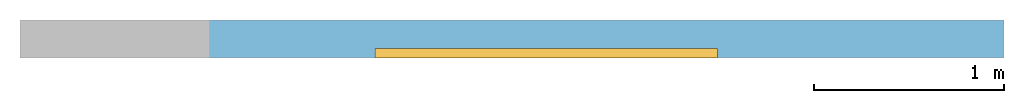
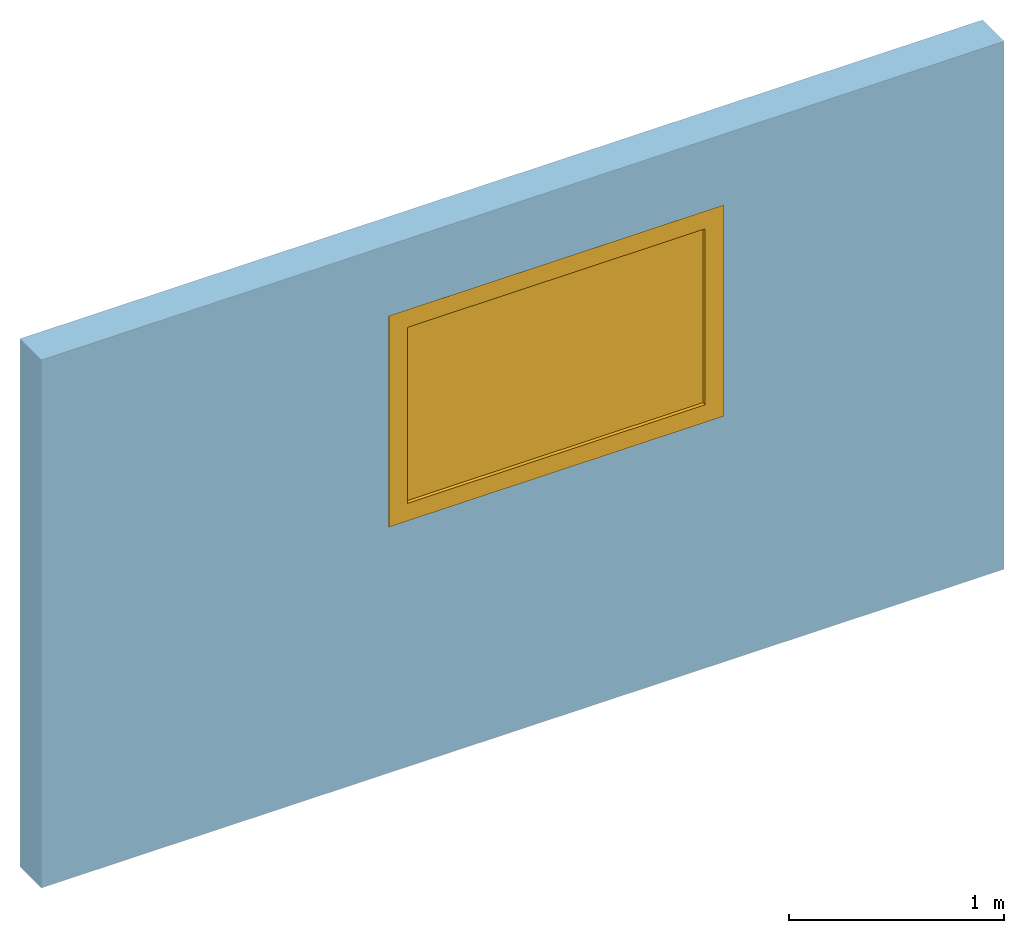
# One storey, part 2 of 2: 1 window, 1 opening, plus 1 element that does not belong to this part.
"""IFC4 building model written with IfcOpenShell, lengths in millimetres."""

import ifcopenshell
import ifcopenshell.guid

model = None  # the IFC model being written
_history = None  # IfcOwnerHistory: only IFC2X3 demands one
_inside = {}  # id of a spatial element -> (the spatial element, [elements in it])
_under = {}  # id of a project, library or spatial element -> (it, [spatial elements below it])
_declared = {}  # id of a project -> (the project, [libraries it declares])
_typed = {}  # id of a type object -> (the type object, [elements of that type])
_made_of = {}  # id of a material, layer set ... -> (it, [elements and type objects made of it])


def new_model(schema):
    """Start an empty IFC model of exactly this schema.

    Asked for "IFC4X3", IfcOpenShell would pick the latest addendum, in which some entities
    have other attributes; the version numbers below select the first issue.
    IFC2X3 requires an IfcOwnerHistory on every rooted entity: one is made here for all.
    """
    global model, _history
    if schema == "IFC4X3":
        model = ifcopenshell.file(schema_version=(4, 3, 0, 0))
    else:
        model = ifcopenshell.file(schema=schema)
    _inside.clear()
    _under.clear()
    _declared.clear()
    _typed.clear()
    _made_of.clear()
    _history = None
    if model.schema == "IFC2X3":
        org = make("IfcOrganization", Name="unknown")
        user = make(
            "IfcPersonAndOrganization",
            ThePerson=make("IfcPerson", FamilyName="unknown"),
            TheOrganization=org,
        )
        app = make(
            "IfcApplication",
            ApplicationDeveloper=org,
            Version="unknown",
            ApplicationFullName="unknown",
            ApplicationIdentifier="unknown",
        )
        _history = make(
            "IfcOwnerHistory",
            OwningUser=user,
            OwningApplication=app,
            ChangeAction="ADDED",
            CreationDate=0,
        )
    return model


def make(cls, **values):
    """One entity of the class cls with the attributes given. An attribute that is None is left unset."""
    return model.create_entity(
        cls, **{name: value for name, value in values.items() if value is not None}
    )


def entity(cls, *values):
    """Any entity or typed value of the class cls, its attributes in the order of the schema. None: left unset."""
    e = model.create_entity(cls)
    for i, value in enumerate(values):
        if value is not None:
            e[i] = value
    return e


def rooted(cls, **values):
    """An entity with a GlobalId (a new one), such as an element, a storey or a relation."""
    return make(cls, GlobalId=ifcopenshell.guid.new(), OwnerHistory=_history, **values)


def si_unit(unit_type, name, prefix=None):
    """IfcSIUnit, for example si_unit("LENGTHUNIT", "METRE", prefix="MILLI")."""
    return make("IfcSIUnit", UnitType=unit_type, Prefix=prefix, Name=name)


def converted_unit(unit_type, name, factor, base, dimensions=None, offset=None):
    """IfcConversionBasedUnit, such as the inch: factor (a typed value) times the base unit."""
    return make(
        "IfcConversionBasedUnit"
        if offset is None
        else "IfcConversionBasedUnitWithOffset",
        ConversionOffset=offset,
        Dimensions=None
        if dimensions is None
        else entity("IfcDimensionalExponents", *dimensions),
        UnitType=unit_type,
        Name=name,
        ConversionFactor=make(
            "IfcMeasureWithUnit", ValueComponent=factor, UnitComponent=base
        ),
    )


def assignment(units):
    """IfcUnitAssignment: the units of a project."""
    return None if units is None else make("IfcUnitAssignment", Units=units)


def point(xyz):
    """IfcCartesianPoint."""
    return None if xyz is None else make("IfcCartesianPoint", Coordinates=xyz)


def direction(xyz):
    """IfcDirection."""
    return None if xyz is None else make("IfcDirection", DirectionRatios=xyz)


def frame(location, z_axis=None, x_axis=None):
    """IfcAxis2Placement3D, a coordinate frame: its origin and axes. An axis left out is left unset."""
    return make(
        "IfcAxis2Placement3D",
        Location=point(location),
        Axis=direction(z_axis),
        RefDirection=direction(x_axis),
    )


def frame_2d(location, x_axis=None):
    """IfcAxis2Placement2D, a coordinate frame in the plane: its origin and x axis."""
    return make(
        "IfcAxis2Placement2D", Location=point(location), RefDirection=direction(x_axis)
    )


def origin_with_axes():
    """The frame at (0, 0, 0) with the z axis (0, 0, 1) and the x axis (1, 0, 0) written out."""
    return frame((0.0, 0.0, 0.0), z_axis=(0.0, 0.0, 1.0), x_axis=(1.0, 0.0, 0.0))


def place(relative_to, where):
    """IfcLocalPlacement: puts the frame where relative to a parent placement (None: the world)."""
    return make(
        "IfcLocalPlacement", PlacementRelTo=relative_to, RelativePlacement=where
    )


def context(
    kind, dimensions, precision=None, world=None, true_north=None, identifier=None
):
    """IfcGeometricRepresentationContext, for example the 3D "Model" context."""
    return make(
        "IfcGeometricRepresentationContext",
        ContextIdentifier=identifier,
        ContextType=kind,
        CoordinateSpaceDimension=dimensions,
        Precision=precision,
        WorldCoordinateSystem=world,
        TrueNorth=true_north,
    )


def subcontext(parent, identifier, kind, view, scale=None):
    """IfcGeometricRepresentationSubContext, for example "Body" below "Model"."""
    return make(
        "IfcGeometricRepresentationSubContext",
        ContextIdentifier=identifier,
        ContextType=kind,
        ParentContext=parent,
        TargetScale=scale,
        TargetView=view,
    )


def project(units=None, contexts=None):
    """IfcProject with its units and contexts."""
    return rooted(
        "IfcProject",
        Name="project",
        RepresentationContexts=contexts,
        UnitsInContext=assignment(units),
    )


def spatial(cls, under=None, at=None, **own):
    """A site, building, storey or space (cls), placed at a placement, below another one or the project."""
    s = rooted(cls, ObjectPlacement=at, **own)
    if under is not None:
        _under.setdefault(under.id(), (under, []))[1].append(s)
    return s


def polyline(points):
    """IfcPolyline through the points."""
    return make("IfcPolyline", Points=[point(p) for p in points])


def point_list(points):
    """IfcCartesianPointList2D or 3D."""
    cls = (
        "IfcCartesianPointList2D" if len(points[0]) == 2 else "IfcCartesianPointList3D"
    )
    return make(cls, CoordList=points)


def outline(outer, holes=None, kind="AREA"):
    """IfcArbitraryClosedProfileDef: a profile drawn as a closed curve; with holes, ...WithVoids."""
    if holes is None:
        return make("IfcArbitraryClosedProfileDef", ProfileType=kind, OuterCurve=outer)
    return make(
        "IfcArbitraryProfileDefWithVoids",
        ProfileType=kind,
        OuterCurve=outer,
        InnerCurves=holes,
    )


def extrude(swept, where, along, depth):
    """IfcExtrudedAreaSolid: the profile swept, set in the frame where, extruded along a direction by depth."""
    return make(
        "IfcExtrudedAreaSolid",
        SweptArea=swept,
        Position=where,
        ExtrudedDirection=direction(along),
        Depth=depth,
    )


def polygons(points, faces, closed=None, point_numbers=None):
    """IfcPolygonalFaceSet: a face is its outer loop, then its inner loops; points numbered from 1."""
    made = []
    for loops in faces:
        if len(loops) == 1:
            made.append(make("IfcIndexedPolygonalFace", CoordIndex=loops[0]))
        else:
            made.append(
                make(
                    "IfcIndexedPolygonalFaceWithVoids",
                    CoordIndex=loops[0],
                    InnerCoordIndices=loops[1:],
                )
            )
    return make(
        "IfcPolygonalFaceSet",
        Coordinates=point_list(points),
        Closed=closed,
        Faces=made,
        PnIndex=point_numbers,
    )


def shape(context_of_items, identifier, shape_type, items):
    """IfcShapeRepresentation: the items that make up one representation, for example the "Body"."""
    return make(
        "IfcShapeRepresentation",
        ContextOfItems=context_of_items,
        RepresentationIdentifier=identifier,
        RepresentationType=shape_type,
        Items=items,
    )


def source(mapping_origin, context_of_items, identifier, shape_type, items):
    """IfcRepresentationMap: a shape defined once, which mapped items show again and again."""
    return make(
        "IfcRepresentationMap",
        MappingOrigin=mapping_origin,
        MappedRepresentation=shape(context_of_items, identifier, shape_type, items),
    )


def transform(
    local_origin,
    x_axis=None,
    y_axis=None,
    z_axis=None,
    scale=None,
    scale2=None,
    scale3=None,
    uniform=True,
):
    """IfcCartesianTransformationOperator3D, or its non-uniform kind. x_axis, y_axis, z_axis: its Axis1, 2, 3."""
    if uniform:
        return make(
            "IfcCartesianTransformationOperator3D",
            Axis1=direction(x_axis),
            Axis2=direction(y_axis),
            LocalOrigin=point(local_origin),
            Scale=scale,
            Axis3=direction(z_axis),
        )
    return make(
        "IfcCartesianTransformationOperator3DnonUniform",
        Axis1=direction(x_axis),
        Axis2=direction(y_axis),
        LocalOrigin=point(local_origin),
        Scale=scale,
        Axis3=direction(z_axis),
        Scale2=scale2,
        Scale3=scale3,
    )


def mapped(mapping_source, mapping_target):
    """IfcMappedItem: shows the shape of a source again, moved by a transform."""
    return make(
        "IfcMappedItem", MappingSource=mapping_source, MappingTarget=mapping_target
    )


def material(Name=None, Category=None):
    """IfcMaterial."""
    return make("IfcMaterial", Name=Name, Category=Category)


def layer(
    of_material, thickness, ventilated=None, Name=None, Category=None, Priority=None
):
    """IfcMaterialLayer: one layer of a wall or slab, of a material (None: an air gap)."""
    return make(
        "IfcMaterialLayer",
        Material=of_material,
        LayerThickness=thickness,
        IsVentilated=ventilated,
        Name=Name,
        Category=Category,
        Priority=Priority,
    )


def layer_set(layers, Name=None):
    """IfcMaterialLayerSet."""
    return make("IfcMaterialLayerSet", MaterialLayers=layers, LayerSetName=Name)


def layer_usage(for_layer_set, set_direction, sense, offset, extent=None):
    """IfcMaterialLayerSetUsage: how a layer set lies in its element."""
    return make(
        "IfcMaterialLayerSetUsage",
        ForLayerSet=for_layer_set,
        LayerSetDirection=set_direction,
        DirectionSense=sense,
        OffsetFromReferenceLine=offset,
        ReferenceExtent=extent,
    )


def made_of(thing, what):
    """Note that an element or type object is made of a material, layer set ...; save() writes the relation."""
    if what is not None:
        _made_of.setdefault(what.id(), (what, []))[1].append(thing)
    return thing


def type_object(cls, material=None, **own):
    """A type object (cls), such as IfcWallType, which elements share."""
    return made_of(rooted(cls, **own), material)


def type_shapes(of_type, sources):
    """Give a type object the sources (RepresentationMaps) that its elements show as mapped items."""
    of_type.RepresentationMaps = sources


def element(
    cls,
    number,
    at=None,
    inside=None,
    cuts=None,
    type_object=None,
    material=None,
    context=None,
    identifier="Body",
    shape_type=None,
    held_by="IfcProductDefinitionShape",
    body=None,
    shapes=None,
    **own,
):
    """One element of the class cls, such as IfcWall. Its Tag is "e" and its number.

    at: its placement. inside: the storey or other place that contains it. cuts: it is an
    opening in that element (IfcRelVoidsElement). A single representation is given by context,
    identifier, shape_type and body (its items); several are given by shapes. held_by: the class
    of the entity that holds the representations. save() writes the other relations.
    """
    e = rooted(cls, Tag="e%d" % number, ObjectPlacement=at, **own)
    if body is not None:
        shapes = [shape(context, identifier, shape_type, body)]
    if shapes is not None:
        e.Representation = make(held_by, Representations=shapes)
    if inside is not None:
        _inside.setdefault(inside.id(), (inside, []))[1].append(e)
    if cuts is not None:
        rooted(
            "IfcRelVoidsElement", RelatingBuildingElement=cuts, RelatedOpeningElement=e
        )
    if type_object is not None:
        _typed.setdefault(type_object.id(), (type_object, []))[1].append(e)
    return made_of(e, material)


def fill(opening, filler):
    """IfcRelFillsElement: the door or window that sits in an opening."""
    return rooted(
        "IfcRelFillsElement",
        RelatingOpeningElement=opening,
        RelatedBuildingElement=filler,
    )


def aggregate(whole, parts):
    """IfcRelAggregates: a whole, such as a stair, and the parts it consists of."""
    return rooted("IfcRelAggregates", RelatingObject=whole, RelatedObjects=parts)


def save(model, path):
    """Write the relations noted so far, then the file.

    IfcRelAggregates (storeys below a building ...), IfcRelContainedInSpatialStructure (elements
    in a storey), IfcRelDefinesByType, IfcRelAssociatesMaterial and IfcRelDeclares: one each for
    every whole, place, type object, material and project.
    """
    for whole, parts in _under.values():
        aggregate(whole, parts)
    for where, things in _inside.values():
        rooted(
            "IfcRelContainedInSpatialStructure",
            RelatedElements=things,
            RelatingStructure=where,
        )
    for kind, things in _typed.values():
        rooted("IfcRelDefinesByType", RelatedObjects=things, RelatingType=kind)
    for what, things in _made_of.values():
        rooted("IfcRelAssociatesMaterial", RelatedObjects=things, RelatingMaterial=what)
    for by, libraries in _declared.values():
        rooted("IfcRelDeclares", RelatingContext=by, RelatedDefinitions=libraries)
    model.write(path)


model = new_model("IFC4")

# Units and contexts
model_context = context("Model", 3, precision=1e-05, world=origin_with_axes())
plan_context = context("Plan", 2, precision=1e-05, world=frame_2d((0.0, 0.0, 0.0), x_axis=(1.0, 0.0, 0.0)))
body_context_1 = subcontext(model_context, "Body", "Model", "MODEL_VIEW")
body_context_2 = subcontext(model_context, "Body", "Model", "MODEL_VIEW")
ifc_project = project(units=[si_unit("VOLUMEUNIT", "CUBIC_METRE", prefix="MILLI"), si_unit("LENGTHUNIT", "METRE", prefix="MILLI"), converted_unit("PLANEANGLEUNIT", "degree", entity("IfcReal", 0.0174532925199433), si_unit("PLANEANGLEUNIT", "RADIAN"), dimensions=[0, 0, 0, 0, 0, 0, 0]), si_unit("AREAUNIT", "SQUARE_METRE", prefix="MILLI")], contexts=[model_context, plan_context])

# Site, building, storey
site_placement = place(None, origin_with_axes())
site = spatial("IfcSite", under=ifc_project, at=site_placement)
building_placement = place(site_placement, origin_with_axes())
building = spatial("IfcBuilding", under=site, at=building_placement, Name="Building")
storey_placement = place(building_placement, origin_with_axes())
storey = spatial("IfcBuildingStorey", under=building, at=storey_placement, Name="Storey")

# Wall, opening, window
ifc_material = material()
ifc_layer = layer(ifc_material, 200.0)
ifc_layer_set = layer_set([ifc_layer])
ifc_layer_usage = layer_usage(ifc_layer_set, "AXIS2", "POSITIVE", 0.0)
wall_type = type_object("IfcWallType", Name="DEMO200", material=ifc_layer_set)
wall_placement = place(storey_placement, origin_with_axes())
wall = element("IfcWall", 1, at=wall_placement, inside=storey, type_object=wall_type, material=ifc_layer_usage, Name="Wall", context=body_context_1, shape_type="SweptSolid", body=[
    extrude(outline(polyline([(-100.000001490116, -2586.58933639526), (100.000001490116, -2586.58933639526), (100.000001490116, 2586.58933639526), (-100.000001490116, 2586.58933639526), (-100.000001490116, -2586.58933639526)])), frame((2586.58933639526, 100.000001490116, 0.0), z_axis=(0.0, 0.0, -1.0), x_axis=(0.0, -1.0, 0.0)), (0.0, 0.0, -1.0), 3000.0),
])
opening_placement = place(wall_placement, frame((1866.46378040314, 0.0, 1397.2282409668), z_axis=(0.0, 0.0, 1.0), x_axis=(1.0, 0.0, 0.0)))
opening = element("IfcOpeningElement", 2, at=opening_placement, cuts=wall, Name="Opening", context=body_context_1, shape_type="Tessellation", body=[
    polygons([(0.0, -99.9999923706055, 0.0), (0.0, -99.9999923706055, 1200.0), (0.0, 300.0, 0.0), (0.0, 300.0, 1200.0), (1799.99963378906, -99.9999923706055, 0.0), (1799.99963378906, -99.9999923706055, 1200.0), (1799.99963378906, 300.0, 0.0), (1799.99963378906, 300.0, 1200.0)], [[[1, 2, 4, 3]], [[3, 4, 8, 7]], [[7, 8, 6, 5]], [[5, 6, 2, 1]], [[3, 7, 5, 1]], [[8, 4, 2, 6]]]),
])
window_type = type_object("IfcWindowType", Name="Window_1800x1200h")
shared_shape = source(origin_with_axes(), body_context_2, "Body", "Tessellation", [
    polygons([(99.9999771118164, 0.0, 99.9999771118164), (1700.0, 0.0, 99.9999771118164), (1700.0, 49.9999923706055, 99.9999771118164), (99.9999771118164, 49.9999923706055, 99.9999771118164), (0.0, 49.9999923706055, 1200.0), (0.0, 0.0, 1200.0), (0.0, 49.9999923706055, 0.0), (0.0, 0.0, 0.0), (1799.99975585938, 0.0, 0.0), (1799.99975585938, 49.9999923706055, 0.0), (1799.99975585938, 49.9999923706055, 1200.0), (1799.99975585938, 0.0, 1200.0), (99.9999771118164, 49.9999923706055, 1100.0), (99.9999771118164, 0.0, 1100.0), (1700.0, 0.0, 1100.0), (1700.0, 49.9999923706055, 1100.0), (1700.0, 19.9999961853027, 1100.0), (99.9999771118164, 19.9999961853027, 1100.0), (99.9999771118164, 19.9999961853027, 99.9999771118164), (1700.0, 19.9999961853027, 99.9999771118164), (1700.0, 29.9999961853027, 99.9999771118164), (99.9999771118164, 29.9999961853027, 99.9999771118164), (99.9999771118164, 29.9999961853027, 1100.0), (1700.0, 29.9999961853027, 1100.0)], [[[3, 1, 2]], [[3, 4, 1]], [[8, 6, 5]], [[8, 5, 7]], [[11, 9, 10]], [[11, 12, 9]], [[13, 1, 4]], [[13, 14, 1]], [[11, 5, 6]], [[11, 6, 12]], [[8, 14, 6]], [[1, 14, 8]], [[12, 6, 14]], [[15, 12, 14]], [[9, 12, 15]], [[7, 10, 9]], [[7, 9, 8]], [[10, 3, 16]], [[10, 16, 11]], [[10, 7, 4]], [[10, 4, 3]], [[13, 4, 7]], [[5, 13, 7]], [[11, 16, 13]], [[11, 13, 5]], [[15, 16, 3]], [[15, 3, 2]], [[9, 15, 2]], [[9, 2, 1]], [[9, 1, 8]], [[13, 16, 15]], [[13, 15, 14]]]),
    polygons([(99.9999771118164, 0.0, 99.9999771118164), (1700.0, 0.0, 99.9999771118164), (1700.0, 49.9999923706055, 99.9999771118164), (99.9999771118164, 49.9999923706055, 99.9999771118164), (0.0, 49.9999923706055, 1200.0), (0.0, 0.0, 1200.0), (0.0, 49.9999923706055, 0.0), (0.0, 0.0, 0.0), (1799.99975585938, 0.0, 0.0), (1799.99975585938, 49.9999923706055, 0.0), (1799.99975585938, 49.9999923706055, 1200.0), (1799.99975585938, 0.0, 1200.0), (99.9999771118164, 49.9999923706055, 1100.0), (99.9999771118164, 0.0, 1100.0), (1700.0, 0.0, 1100.0), (1700.0, 49.9999923706055, 1100.0), (1700.0, 19.9999961853027, 1100.0), (99.9999771118164, 19.9999961853027, 1100.0), (99.9999771118164, 19.9999961853027, 99.9999771118164), (1700.0, 19.9999961853027, 99.9999771118164), (1700.0, 29.9999961853027, 99.9999771118164), (99.9999771118164, 29.9999961853027, 99.9999771118164), (99.9999771118164, 29.9999961853027, 1100.0), (1700.0, 29.9999961853027, 1100.0)], [[[20, 17, 18]], [[20, 18, 19]], [[19, 22, 21]], [[19, 21, 20]], [[24, 21, 22]], [[24, 22, 23]], [[24, 17, 20]], [[24, 20, 21]], [[23, 18, 17]], [[23, 17, 24]], [[18, 23, 22]], [[18, 22, 19]]]),
])
type_shapes(window_type, [shared_shape])
window_placement = place(storey_placement, frame((1866.46378040314, 0.0, 1397.2282409668), z_axis=(0.0, 0.0, 1.0), x_axis=(1.0, 0.0, 0.0)))
window = element("IfcWindow", 3, at=window_placement, inside=storey, type_object=window_type, Name="Window", context=body_context_2, shape_type="MappedRepresentation", body=[
    mapped(shared_shape, transform((0.0, 0.0, 0.0), x_axis=(1.0, 0.0, 0.0), y_axis=(0.0, 1.0, 0.0), z_axis=(0.0, 0.0, 1.0), scale=1.0)),
])
fill(opening, window)

save(model, "model.ifc")
